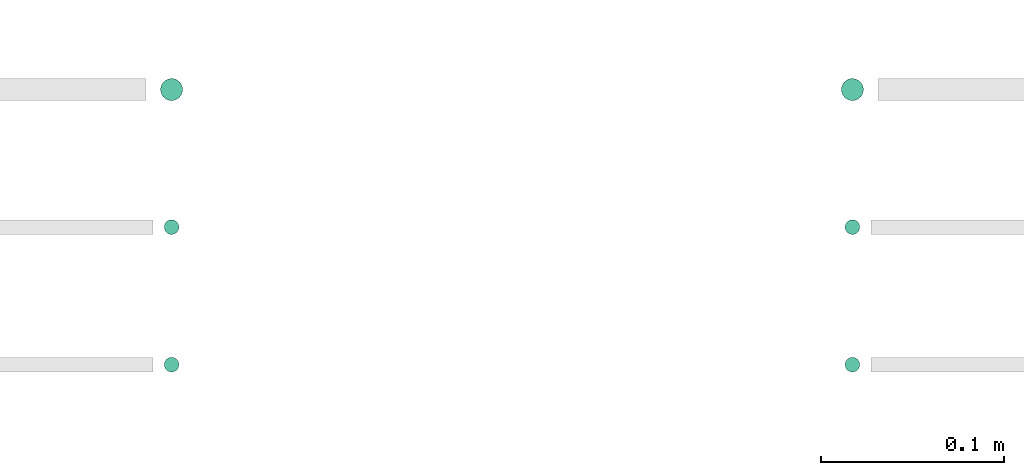
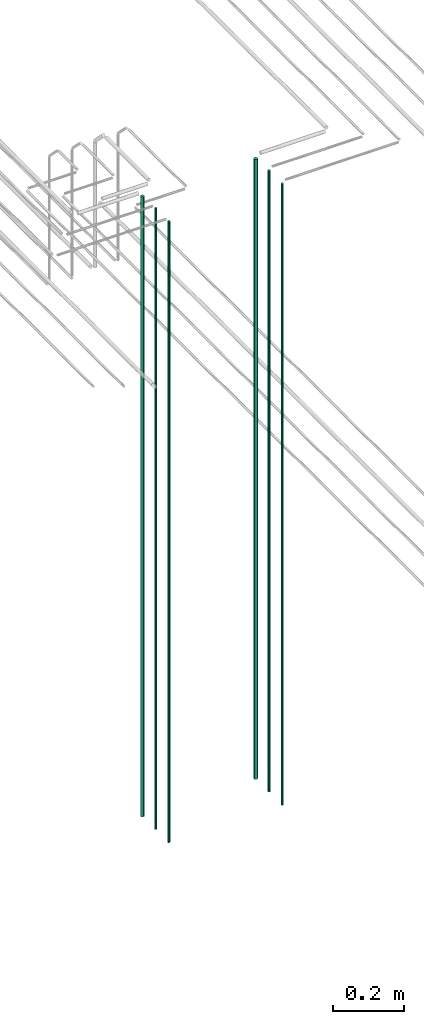
# One storey, part 17 of 331: 6 flow segments.
"""IFC2X3 building model written with IfcOpenShell, lengths in millimetres."""

from ifc_helpers import new_model, entity, si_unit, converted_unit, derived_unit, direction, frame, origin, origin_2d_with_axis, place, context, subcontext, project, spatial, circle, extrude, type_object, element, save


model = new_model("IFC2X3")

# Units and contexts
model_context = context("Model", 3, precision=0.01, world=origin(), true_north=direction((6.12303176911189e-17, 1.0)))
body_context = subcontext(model_context, "Body", "Model", "MODEL_VIEW")
ifc_project = project(units=[si_unit("LENGTHUNIT", "METRE", prefix="MILLI"), si_unit("AREAUNIT", "SQUARE_METRE"), si_unit("VOLUMEUNIT", "CUBIC_METRE"), converted_unit("PLANEANGLEUNIT", "DEGREE", entity("IfcRatioMeasure", 0.0174532925199433), si_unit("PLANEANGLEUNIT", "RADIAN"), dimensions=[0, 0, 0, 0, 0, 0, 0]), si_unit("MASSUNIT", "GRAM", prefix="KILO"), derived_unit("MASSDENSITYUNIT", [(si_unit("MASSUNIT", "GRAM", prefix="KILO"), 1), (si_unit("LENGTHUNIT", "METRE"), -3)]), derived_unit("MOMENTOFINERTIAUNIT", [(si_unit("LENGTHUNIT", "METRE"), 4)]), si_unit("TIMEUNIT", "SECOND"), si_unit("FREQUENCYUNIT", "HERTZ"), si_unit("THERMODYNAMICTEMPERATUREUNIT", "DEGREE_CELSIUS"), derived_unit("THERMALTRANSMITTANCEUNIT", [(si_unit("MASSUNIT", "GRAM", prefix="KILO"), 1), (si_unit("THERMODYNAMICTEMPERATUREUNIT", "KELVIN"), -1), (si_unit("TIMEUNIT", "SECOND"), -3)]), derived_unit("VOLUMETRICFLOWRATEUNIT", [(si_unit("LENGTHUNIT", "METRE"), 3), (si_unit("TIMEUNIT", "SECOND"), -1)]), derived_unit("MASSFLOWRATEUNIT", [(si_unit("MASSUNIT", "GRAM", prefix="KILO"), 1), (si_unit("TIMEUNIT", "SECOND"), -1)]), derived_unit("ROTATIONALFREQUENCYUNIT", [(si_unit("TIMEUNIT", "SECOND"), -1)]), si_unit("ELECTRICCURRENTUNIT", "AMPERE"), si_unit("ELECTRICVOLTAGEUNIT", "VOLT"), si_unit("POWERUNIT", "WATT"), si_unit("FORCEUNIT", "NEWTON", prefix="KILO"), si_unit("ILLUMINANCEUNIT", "LUX"), si_unit("LUMINOUSFLUXUNIT", "LUMEN"), si_unit("LUMINOUSINTENSITYUNIT", "CANDELA"), derived_unit("USERDEFINED", [(si_unit("MASSUNIT", "GRAM", prefix="KILO"), -1), (si_unit("LENGTHUNIT", "METRE"), -2), (si_unit("TIMEUNIT", "SECOND"), 3), (si_unit("LUMINOUSFLUXUNIT", "LUMEN"), 1)]), derived_unit("LINEARVELOCITYUNIT", [(si_unit("LENGTHUNIT", "METRE"), 1), (si_unit("TIMEUNIT", "SECOND"), -1)]), si_unit("PRESSUREUNIT", "PASCAL"), derived_unit("USERDEFINED", [(si_unit("LENGTHUNIT", "METRE"), -2), (si_unit("MASSUNIT", "GRAM", prefix="KILO"), 1), (si_unit("TIMEUNIT", "SECOND"), -2)]), derived_unit("LINEARFORCEUNIT", [(si_unit("MASSUNIT", "GRAM", prefix="KILO"), 1), (si_unit("LENGTHUNIT", "METRE"), 1), (si_unit("TIMEUNIT", "SECOND"), -2), (si_unit("LENGTHUNIT", "METRE"), -1)]), derived_unit("PLANARFORCEUNIT", [(si_unit("MASSUNIT", "GRAM", prefix="KILO"), 1), (si_unit("LENGTHUNIT", "METRE"), 1), (si_unit("TIMEUNIT", "SECOND"), -2), (si_unit("LENGTHUNIT", "METRE"), -2)])], contexts=[model_context])

# Site, building, storey
site_placement = place(None, frame((0.0, -0.00077364408347762, 0.0)))
site = spatial("IfcSite", under=ifc_project, at=site_placement, CompositionType="ELEMENT")
building_placement = place(site_placement, origin())
building = spatial("IfcBuilding", under=site, at=building_placement, CompositionType="ELEMENT")
storey_placement = place(building_placement, origin())
storey = spatial("IfcBuildingStorey", under=building, at=storey_placement, CompositionType="ELEMENT", Elevation=0.0)

# Flow segments
pipe_segment_type = type_object("IfcPipeSegmentType", PredefinedType="NOTDEFINED")
flow_segment_1_placement = place(storey_placement, frame((35149.1379388917, 3883.89349484338, 12990.0)))
element("IfcFlowSegment", 1, at=flow_segment_1_placement, inside=storey, type_object=pipe_segment_type, context=body_context, shape_type="SweptSolid", body=[
    extrude(circle(Radius=6.0, at=origin_2d_with_axis()), frame((7.59527223591454, 7.59527223591616, 0.0)), (0.0, 0.0, 1.0), 2146.00000000001),
])
for number, where in (
    (2, (35151.1379388917, 3735.89349484312, 12990.0)),
    (3, (35151.1379388917, 3810.89349484385, 12990.0)),
):
    element("IfcFlowSegment", number, at=place(storey_placement, frame(where)), inside=storey, type_object=pipe_segment_type, context=body_context, shape_type="SweptSolid", body=[
        extrude(circle(Radius=4.0, at=origin_2d_with_axis()), frame((5.59527223591499, 5.59527223591607, 0.0)), (0.0, 0.0, 1.0), 2150.00000000001),
    ])
flow_segment_2_placement = place(storey_placement, frame((34777.8885865545, 3883.8934948434, 12990.0)))
element("IfcFlowSegment", 4, at=flow_segment_2_placement, inside=storey, type_object=pipe_segment_type, context=body_context, shape_type="SweptSolid", body=[
    extrude(circle(Radius=6.0, at=origin_2d_with_axis()), frame((7.59527223591454, 7.59527223591616, 0.0)), (0.0, 0.0, 1.0), 2146.0),
])
for number, where in (
    (5, (34779.8885865545, 3735.89349484316, 12990.0)),
    (6, (34779.8885865545, 3810.89349484385, 12990.0)),
):
    element("IfcFlowSegment", number, at=place(storey_placement, frame(where)), inside=storey, type_object=pipe_segment_type, context=body_context, shape_type="SweptSolid", body=[
        extrude(circle(Radius=4.0, at=origin_2d_with_axis()), frame((5.59527223591499, 5.59527223591607, 0.0)), (0.0, 0.0, 1.0), 2150.00000000001),
    ])

save(model, "model.ifc")
